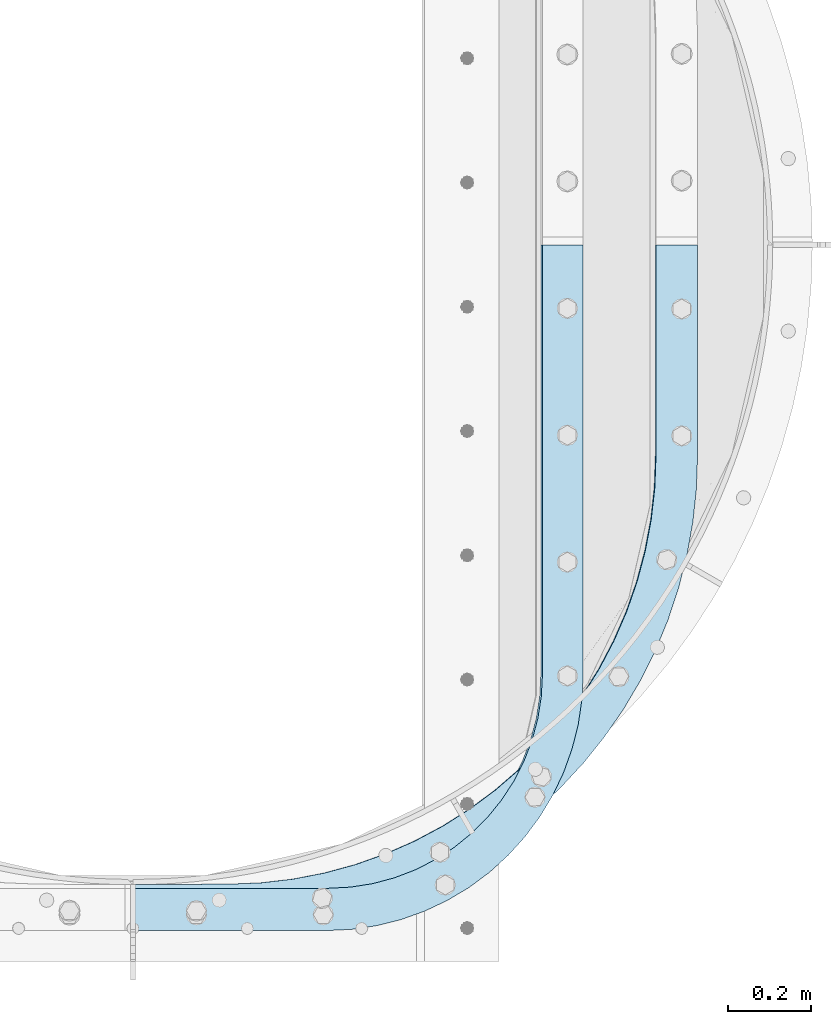
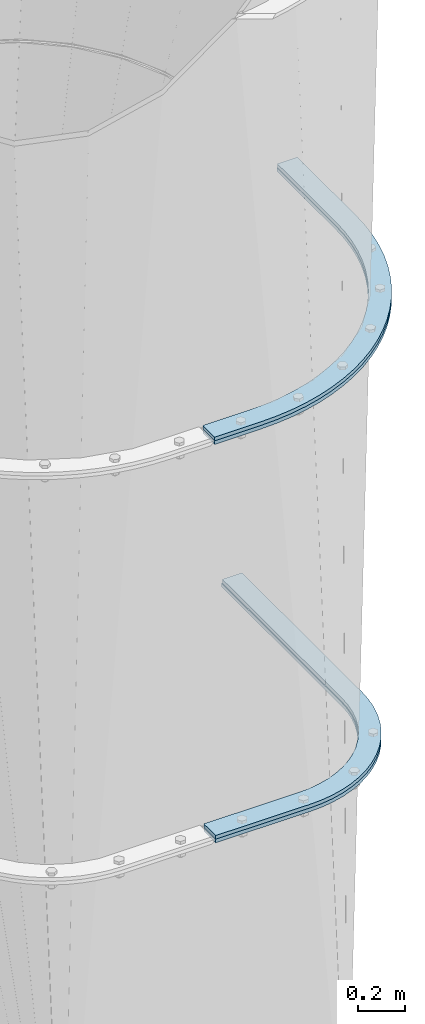
# One storey, part 11 of 15: 4 plates, 3 elements without a shape of their own.
"""IFC2X3 building model written with IfcOpenShell, lengths in millimetres."""

from ifc_helpers import new_model, si_unit, frame, origin_with_axes, place, context, subcontext, project, spatial, faceted_brep, material, type_object, element, aggregate, save


model = new_model("IFC2X3")

# Units and contexts
model_context = context("Model", 3, precision=1e-05, world=origin_with_axes())
body_context = subcontext(model_context, "Body", "Model", "MODEL_VIEW")
ifc_project = project(units=[si_unit("LENGTHUNIT", "METRE", prefix="MILLI"), si_unit("AREAUNIT", "SQUARE_METRE"), si_unit("VOLUMEUNIT", "CUBIC_METRE"), si_unit("MASSUNIT", "GRAM", prefix="KILO"), si_unit("TIMEUNIT", "SECOND"), si_unit("PLANEANGLEUNIT", "RADIAN"), si_unit("SOLIDANGLEUNIT", "STERADIAN"), si_unit("THERMODYNAMICTEMPERATUREUNIT", "DEGREE_CELSIUS"), si_unit("LUMINOUSINTENSITYUNIT", "LUMEN")], contexts=[model_context])

# Site, building, storey
site_placement = place(None, origin_with_axes())
site = spatial("IfcSite", under=ifc_project, at=site_placement, CompositionType="ELEMENT")
building_placement = place(site_placement, origin_with_axes())
building = spatial("IfcBuilding", under=site, at=building_placement, Name="Undefined", CompositionType="ELEMENT")
storey_placement = place(building_placement, origin_with_axes())
storey = spatial("IfcBuildingStorey", under=building, at=storey_placement, Name="Undefined", CompositionType="ELEMENT", Elevation=0.0)

# Assembly, plate
assembly_1_placement = place(storey_placement, origin_with_axes())
assembly_1 = element("IfcElementAssembly", 1, at=assembly_1_placement, inside=storey, Name="TRANSITION", AssemblyPlace="NOTDEFINED", PredefinedType="RIGID_FRAME")
ifc_material = material(Name="STEEL/A36")
plate_type_1 = type_object("IfcPlateType", PredefinedType="NOTDEFINED")
plate_1_placement = place(assembly_1_placement, frame((2235.57307813265, 1720.82092583339, 4192.06000019074), z_axis=(0.0, -1.0, 0.0), x_axis=(-1.0, 0.0, 0.0)))
plate_1 = element("IfcPlate", 2, at=plate_1_placement, type_object=plate_type_1, material=ifc_material, Name="PLATE", context=body_context, shape_type="Brep", body=[
    faceted_brep([(0.0, -9.52499999999964, 0.0), (0.00226665040457874, -9.52499999999964, 506.568496906642), (0.00226665040457874, 9.52499999999964, 506.568496906642), (0.0, 9.52499999999964, 0.0), (2.86552112687696, -9.52499999999964, 586.965399212112), (2.86552112687696, 9.52499999999964, 586.965399212112), (11.4400606208065, -9.52499999999964, 666.955007280796), (11.4400606208065, 9.52499999999964, 666.955007280796), (25.682448871113, -9.52499999999964, 746.132115736726), (25.682448871113, 9.52499999999964, 746.132115736726), (45.5205378522613, -9.52499999999964, 824.095635103739), (45.5205378522613, 9.52499999999964, 824.095635103739), (70.8538332563299, -9.52499999999964, 900.450623614542), (70.8538332563299, 9.52499999999964, 900.450623614542), (101.554003569561, -9.52499999999964, 974.810287877187), (101.554003569561, 9.52499999999964, 974.810287877187), (137.465530164548, -9.52499999999964, 1046.79794226412), (137.465530164548, 9.52499999999964, 1046.79794226412), (178.406495114871, -9.52499999999964, 1116.04891709806), (178.406495114871, 9.52499999999964, 1116.04891709806), (224.169502741328, -9.52499999999964, 1182.2124059684), (224.169502741328, 9.52499999999964, 1182.2124059684), (274.522730221457, -9.52499999999964, 1244.95324282008), (274.522730221457, 9.52499999999964, 1244.95324282008), (329.211101940261, -9.52499999999964, 1303.95359981273), (329.211101940261, 9.52499999999964, 1303.95359981273), (387.957581633183, -9.52499999999964, 1358.9145973492), (387.957581633183, 9.52499999999964, 1358.9145973492), (450.464575775707, -9.52499999999964, 1409.55781811744), (450.464575775707, 9.52499999999964, 1409.55781811744), (516.41544111038, -9.52499999999964, 1455.62671747614), (516.41544111038, 9.52499999999964, 1455.62671747614), (585.476088674554, -9.52499999999964, 1496.88792303938), (585.476088674554, 9.52499999999964, 1496.88792303938), (657.296676203268, -9.52499999999964, 1533.13241687699), (657.296676203268, 9.52499999999964, 1533.13241687699), (731.513380334047, -9.52499999999964, 1564.176594342), (731.513380334047, 9.52499999999964, 1564.176594342), (807.750239636084, -9.52499999999964, 1589.86319416129), (807.750239636084, 9.52499999999964, 1589.86319416129), (885.621059127542, -9.52499999999964, 1610.062095078), (885.621059127542, 9.52499999999964, 1610.062095078), (964.731366633227, -9.52499999999964, 1624.6709750101), (964.731366633227, 9.52499999999964, 1624.6709750101), (1044.68041107224, -9.52499999999964, 1633.61582938589), (1044.68041107224, 9.52499999999964, 1633.61582938589), (1125.06319255282, -9.52499999999964, 1636.85134603082), (1125.06319255282, 9.52499999999964, 1636.85134603082), (1356.09802246094, -9.52499999999964, 1637.92224121094), (1356.09802246094, 9.52499999999964, 1637.92224121094), (1356.09802246094, -9.52499999999964, 1536.322265625), (1356.09802246094, 9.52499999999964, 1536.322265625), (1123.73482538487, -9.52499999999964, 1535.24674210153), (1123.73482538487, 9.52499999999964, 1535.24674210153), (1047.10030478318, -9.52499999999964, 1532.03247607219), (1047.10030478318, 9.52499999999964, 1532.03247607219), (970.918303938195, -9.52499999999964, 1523.11709603465), (970.918303938195, 9.52499999999964, 1523.11709603465), (895.612355762711, -9.52499999999964, 1508.55016693653), (895.612355762711, 9.52499999999964, 1508.55016693653), (821.601122765285, -9.52499999999964, 1488.41267344407), (821.601122765285, 9.52499999999964, 1488.41267344407), (749.2960695011, -9.52499999999964, 1462.8165697089), (749.2960695011, 9.52499999999964, 1462.8165697089), (679.099175039733, -9.52499999999964, 1431.90415696032), (679.099175039733, 9.52499999999964, 1431.90415696032), (611.400698167385, -9.52499999999964, 1395.84729238334), (611.400698167385, 9.52499999999964, 1395.84729238334), (546.57700774787, -9.52499999999964, 1354.84643368071), (546.57700774787, 9.52499999999964, 1354.84643368071), (484.988490304467, -9.52499999999964, 1309.12952463074), (484.988490304467, 9.52499999999964, 1309.12952463074), (426.977546455406, -9.52499999999964, 1258.95072783668), (426.977546455406, 9.52499999999964, 1258.95072783668), (372.866687341763, -9.52499999999964, 1204.58901171272), (372.866687341763, 9.52499999999964, 1204.58901171272), (322.956741630674, -9.52499999999964, 1146.34659956251), (322.956741630674, 9.52499999999964, 1146.34659956251), (277.525183061995, -9.52499999999964, 1084.54728937235), (277.525183061995, 9.52499999999964, 1084.54728937235), (236.824587836399, -9.52499999999964, 1019.5346536602), (236.824587836399, 9.52499999999964, 1019.5346536602), (201.081230421042, -9.52499999999964, 951.670129388405), (201.081230421042, 9.52499999999964, 951.670129388405), (170.493825579402, -9.52499999999964, 881.331008559293), (170.493825579402, 9.52499999999964, 881.331008559293), (145.232423618945, -9.52499999999964, 808.908340664835), (145.232423618945, 9.52499999999964, 808.908340664835), (125.437464998504, -9.52499999999964, 734.804758651724), (125.437464998504, 9.52499999999964, 734.804758651724), (111.218999551242, -9.52499999999964, 659.432240488378), (111.218999551242, 9.52499999999964, 659.432240488378), (102.656074663938, -9.52499999999964, 583.209818778404), (102.656074663938, 9.52499999999964, 583.209818778404), (99.7962958139181, -9.52499999999964, 506.561251153978), (99.7962958139181, 9.52499999999964, 506.561251153978), (99.7946014404297, -9.52499999999964, 0.0), (99.7946014404297, 9.52499999999964, 0.0)], [[[0, 1, 2, 3]], [[1, 4, 5, 2]], [[4, 6, 7, 5]], [[6, 8, 9, 7]], [[8, 10, 11, 9]], [[10, 12, 13, 11]], [[12, 14, 15, 13]], [[14, 16, 17, 15]], [[16, 18, 19, 17]], [[18, 20, 21, 19]], [[20, 22, 23, 21]], [[22, 24, 25, 23]], [[24, 26, 27, 25]], [[26, 28, 29, 27]], [[28, 30, 31, 29]], [[30, 32, 33, 31]], [[32, 34, 35, 33]], [[34, 36, 37, 35]], [[36, 38, 39, 37]], [[38, 40, 41, 39]], [[40, 42, 43, 41]], [[42, 44, 45, 43]], [[44, 46, 47, 45]], [[46, 48, 49, 47]], [[48, 50, 51, 49]], [[50, 52, 53, 51]], [[52, 54, 55, 53]], [[54, 56, 57, 55]], [[56, 58, 59, 57]], [[58, 60, 61, 59]], [[60, 62, 63, 61]], [[62, 64, 65, 63]], [[64, 66, 67, 65]], [[66, 68, 69, 67]], [[68, 70, 71, 69]], [[70, 72, 73, 71]], [[72, 74, 75, 73]], [[74, 76, 77, 75]], [[76, 78, 79, 77]], [[78, 80, 81, 79]], [[80, 82, 83, 81]], [[82, 84, 85, 83]], [[84, 86, 87, 85]], [[86, 88, 89, 87]], [[88, 90, 91, 89]], [[90, 92, 93, 91]], [[92, 94, 95, 93]], [[94, 96, 97, 95]], [[96, 0, 3, 97]], [[5, 7, 9, 11, 13, 15, 17, 19, 21, 23, 25, 27, 29, 31, 33, 35, 37, 39, 41, 43, 45, 47, 49, 51, 53, 55, 57, 59, 61, 63, 65, 67, 69, 71, 73, 75, 77, 79, 81, 83, 85, 87, 89, 91, 93, 95, 97, 3, 2]], [[96, 94, 92, 90, 88, 86, 84, 82, 80, 78, 76, 74, 72, 70, 68, 66, 64, 62, 60, 58, 56, 54, 52, 50, 48, 46, 44, 42, 40, 38, 36, 34, 32, 30, 28, 26, 24, 22, 20, 18, 16, 14, 12, 10, 8, 6, 4, 1, 0]]]),
])
aggregate(assembly_1, [plate_1])

# Assembly, plates
assembly_2_placement = place(storey_placement, origin_with_axes())
assembly_2 = element("IfcElementAssembly", 3, at=assembly_2_placement, inside=storey, Name="TRANSITION", AssemblyPlace="NOTDEFINED", PredefinedType="RIGID_FRAME")
plate_2_placement = place(assembly_2_placement, frame((2235.57307813265, 1720.82092583339, 4173.01), z_axis=(0.0, -1.0, 0.0), x_axis=(-1.0, 0.0, 0.0)))
plate_2 = element("IfcPlate", 4, at=plate_2_placement, type_object=plate_type_1, material=ifc_material, Name="PLATE", context=body_context, shape_type="Brep", body=[
    faceted_brep([(0.0, -9.52499999999964, 0.0), (0.00226665040457874, -9.52499999999964, 506.568496906642), (0.00226665040457874, 9.52499999999964, 506.568496906642), (0.0, 9.52499999999964, 0.0), (2.86552112687696, -9.52499999999964, 586.965399212112), (2.86552112687696, 9.52499999999964, 586.965399212112), (11.4400606208065, -9.52499999999964, 666.955007280796), (11.4400606208065, 9.52499999999964, 666.955007280796), (25.682448871113, -9.52499999999964, 746.132115736726), (25.682448871113, 9.52499999999964, 746.132115736726), (45.5205378522613, -9.52499999999964, 824.095635103739), (45.5205378522613, 9.52499999999964, 824.095635103739), (70.8538332563299, -9.52499999999964, 900.450623614542), (70.8538332563299, 9.52499999999964, 900.450623614542), (101.554003569561, -9.52499999999964, 974.810287877187), (101.554003569561, 9.52499999999964, 974.810287877187), (137.465530164548, -9.52499999999964, 1046.79794226412), (137.465530164548, 9.52499999999964, 1046.79794226412), (178.406495114871, -9.52499999999964, 1116.04891709806), (178.406495114871, 9.52499999999964, 1116.04891709806), (224.169502741328, -9.52499999999964, 1182.2124059684), (224.169502741328, 9.52499999999964, 1182.2124059684), (274.522730221457, -9.52499999999964, 1244.95324282008), (274.522730221457, 9.52499999999964, 1244.95324282008), (329.211101940261, -9.52499999999964, 1303.95359981273), (329.211101940261, 9.52499999999964, 1303.95359981273), (387.957581633183, -9.52499999999964, 1358.9145973492), (387.957581633183, 9.52499999999964, 1358.9145973492), (450.464575775707, -9.52499999999964, 1409.55781811744), (450.464575775707, 9.52499999999964, 1409.55781811744), (516.41544111038, -9.52499999999964, 1455.62671747614), (516.41544111038, 9.52499999999964, 1455.62671747614), (585.476088674554, -9.52499999999964, 1496.88792303938), (585.476088674554, 9.52499999999964, 1496.88792303938), (657.296676203268, -9.52499999999964, 1533.13241687699), (657.296676203268, 9.52499999999964, 1533.13241687699), (731.513380334047, -9.52499999999964, 1564.176594342), (731.513380334047, 9.52499999999964, 1564.176594342), (807.750239636084, -9.52499999999964, 1589.86319416129), (807.750239636084, 9.52499999999964, 1589.86319416129), (885.621059127542, -9.52499999999964, 1610.062095078), (885.621059127542, 9.52499999999964, 1610.062095078), (964.731366633227, -9.52499999999964, 1624.6709750101), (964.731366633227, 9.52499999999964, 1624.6709750101), (1044.68041107224, -9.52499999999964, 1633.61582938589), (1044.68041107224, 9.52499999999964, 1633.61582938589), (1125.06319255282, -9.52499999999964, 1636.85134603082), (1125.06319255282, 9.52499999999964, 1636.85134603082), (1356.09802246094, -9.52499999999964, 1637.92224121094), (1356.09802246094, 9.52499999999964, 1637.92224121094), (1356.09802246094, -9.52499999999964, 1536.322265625), (1356.09802246094, 9.52499999999964, 1536.322265625), (1125.53337021302, -9.52499999999964, 1535.25353104851), (1125.53337021302, 9.52499999999964, 1535.25353104851), (1048.89919630054, -9.52499999999964, 1532.03878036735), (1048.89919630054, 9.52499999999964, 1532.03878036735), (972.717574464455, -9.52499999999964, 1523.1229670218), (972.717574464455, 9.52499999999964, 1523.1229670218), (897.41203190946, -9.52499999999964, 1508.55565794681), (897.41203190946, 9.52499999999964, 1508.55565794681), (823.401225329481, -9.52499999999964, 1488.41783923252), (823.401225329481, 9.52499999999964, 1488.41783923252), (751.096613410651, -9.52499999999964, 1462.82146588676), (751.096613410651, 9.52499999999964, 1462.82146588676), (680.900169351152, -9.52499999999964, 1431.90883942782), (680.900169351152, 9.52499999999964, 1431.90883942782), (613.202146115094, -9.52499999999964, 1395.85181676761), (613.202146115094, 9.52499999999964, 1395.85181676761), (548.378906844311, -9.52499999999964, 1354.8508547834), (548.378906844311, 9.52499999999964, 1354.8508547834), (486.790832489823, -9.52499999999964, 1309.13389588963), (486.790832489823, 9.52499999999964, 1309.13389588963), (428.780318295328, -9.52499999999964, 1258.95510080566), (428.780318295328, 9.52499999999964, 1258.95510080566), (374.669870271166, -9.52499999999964, 1204.59343556431), (374.669870271166, 9.52499999999964, 1204.59343556431), (324.7603122413, -9.52499999999964, 1146.35112061673), (324.7603122413, 9.52499999999964, 1146.35112061673), (279.32911343112, -9.52499999999964, 1084.55195065581), (279.32911343112, 9.52499999999964, 1084.55195065581), (238.628845893756, -9.52499999999964, 1019.53949449874), (238.628845893756, 9.52499999999964, 1019.53949449874), (202.885780350741, -9.52499999999964, 951.67518503657), (202.885780350741, 9.52499999999964, 951.67518503657), (172.298628253365, -9.52499999999964, 881.336309869553), (172.298628253365, 9.52499999999964, 881.336309869553), (147.037437058154, -9.52499999999964, 808.913913799081), (147.037437058154, 9.52499999999964, 808.913913799081), (127.242644858133, -9.52499999999964, 734.810624837339), (127.242644858133, 9.52499999999964, 734.810624837339), (113.024299625579, -9.52499999999964, 659.438415820769), (113.024299625579, 9.52499999999964, 659.438415820769), (104.461447406857, -9.52499999999964, 583.21631407154), (104.461447406857, 9.52499999999964, 583.21631407154), (101.601692870424, -9.52499999999964, 506.568071840215), (101.601692870424, 9.52499999999964, 506.568071840215), (101.599998474121, -9.52499999999964, 0.0), (101.599998474121, 9.52499999999964, 0.0)], [[[0, 1, 2, 3]], [[1, 4, 5, 2]], [[4, 6, 7, 5]], [[6, 8, 9, 7]], [[8, 10, 11, 9]], [[10, 12, 13, 11]], [[12, 14, 15, 13]], [[14, 16, 17, 15]], [[16, 18, 19, 17]], [[18, 20, 21, 19]], [[20, 22, 23, 21]], [[22, 24, 25, 23]], [[24, 26, 27, 25]], [[26, 28, 29, 27]], [[28, 30, 31, 29]], [[30, 32, 33, 31]], [[32, 34, 35, 33]], [[34, 36, 37, 35]], [[36, 38, 39, 37]], [[38, 40, 41, 39]], [[40, 42, 43, 41]], [[42, 44, 45, 43]], [[44, 46, 47, 45]], [[46, 48, 49, 47]], [[48, 50, 51, 49]], [[50, 52, 53, 51]], [[52, 54, 55, 53]], [[54, 56, 57, 55]], [[56, 58, 59, 57]], [[58, 60, 61, 59]], [[60, 62, 63, 61]], [[62, 64, 65, 63]], [[64, 66, 67, 65]], [[66, 68, 69, 67]], [[68, 70, 71, 69]], [[70, 72, 73, 71]], [[72, 74, 75, 73]], [[74, 76, 77, 75]], [[76, 78, 79, 77]], [[78, 80, 81, 79]], [[80, 82, 83, 81]], [[82, 84, 85, 83]], [[84, 86, 87, 85]], [[86, 88, 89, 87]], [[88, 90, 91, 89]], [[90, 92, 93, 91]], [[92, 94, 95, 93]], [[94, 96, 97, 95]], [[96, 0, 3, 97]], [[5, 7, 9, 11, 13, 15, 17, 19, 21, 23, 25, 27, 29, 31, 33, 35, 37, 39, 41, 43, 45, 47, 49, 51, 53, 55, 57, 59, 61, 63, 65, 67, 69, 71, 73, 75, 77, 79, 81, 83, 85, 87, 89, 91, 93, 95, 97, 3, 2]], [[96, 94, 92, 90, 88, 86, 84, 82, 80, 78, 76, 74, 72, 70, 68, 66, 64, 62, 60, 58, 56, 54, 52, 50, 48, 46, 44, 42, 40, 38, 36, 34, 32, 30, 28, 26, 24, 22, 20, 18, 16, 14, 12, 10, 8, 6, 4, 1, 0]]]),
])
plate_type_2 = type_object("IfcPlateType", PredefinedType="NOTDEFINED")
plate_3_placement = place(assembly_2_placement, frame((1960.91443882889, 73.9726734030219, 2110.315), z_axis=(-1.0, 0.0, 0.0), x_axis=(0.0, 1.0, 0.0)))
plate_3 = element("IfcPlate", 5, at=plate_3_placement, type_object=plate_type_2, material=ifc_material, Name="PLATE", context=body_context, shape_type="Brep", body=[
    faceted_brep([(-5.43179524470361e-07, -9.52500000000009, 615.950011663852), (-9.5367431640625e-07, -9.52500000000009, 1081.43933105469), (-1.52587881530053e-06, 9.52500000000009, 1081.43933105469), (-5.43179524470361e-07, 9.52500000000009, 615.950011663852), (101.599998474121, -9.52500000000009, 1081.43933105469), (101.599998474121, 9.52500000000009, 1081.43933105469), (101.599998474121, -9.52500000000009, 612.179878234863), (101.599998474121, 9.52500000000009, 612.179878234863), (104.417661457707, -9.52500000000009, 558.41566570511), (104.417661457707, 9.52500000000009, 558.41566570511), (112.839779503182, -9.52500000000009, 505.240505138718), (112.839779503182, 9.52500000000009, 505.240505138718), (126.7740781228, -9.52500000000009, 453.236994722469), (126.7740781228, 9.52500000000009, 453.236994722469), (146.067890224943, -9.52500000000009, 402.974895798919), (146.067890224943, 9.52500000000009, 402.974895798919), (170.509828766731, -9.52500000000009, 355.004890441895), (170.509828766731, 9.52500000000009, 355.004890441895), (199.832102754696, -9.52500000000009, 309.852548068456), (199.832102754696, 9.52500000000009, 309.852548068456), (233.713451218945, -9.52500000000009, 268.012567190381), (233.713451218945, 9.52500000000009, 268.012567190381), (271.782663015576, -9.52500000000009, 229.94335539375), (271.782663015576, 9.52500000000009, 229.94335539375), (313.622643893651, -9.52500000000009, 196.062006929501), (313.622643893651, 9.52500000000009, 196.062006929501), (358.77498626709, -9.52500000000009, 166.739732941536), (358.77498626709, 9.52500000000009, 166.739732941536), (406.744991624115, -9.52500000000009, 142.297794399747), (406.744991624115, 9.52500000000009, 142.297794399747), (457.007090547665, -9.52500000000009, 123.003982297604), (457.007090547665, 9.52500000000009, 123.003982297604), (509.010600963913, -9.52500000000009, 109.069683677987), (509.010600963913, 9.52500000000009, 109.069683677987), (562.185761530305, -9.52500000000009, 100.647565632512), (562.185761530305, 9.52500000000009, 100.647565632512), (615.949974060059, -9.52500000000009, 97.8299026489258), (615.949974060059, 9.52500000000009, 97.8299026489258), (1646.87729611779, -9.52500114440909, 97.8299026491594), (1646.87731933594, 9.52500000000009, 97.8299026489258), (1646.87731933594, -9.52500000000009, 0.0), (1646.87731933594, 9.52500000000009, 0.0), (615.950011663852, -9.52500000000009, 0.0), (615.950011663852, 9.52500000000009, 0.0), (555.576352915146, -9.52500000000009, 2.96596766171297), (555.576352915146, 9.52500000000009, 2.96596766171297), (495.784125503137, -9.52500000000009, 11.8353067569387), (495.784125503137, 9.52500000000009, 11.8353067569387), (437.149161262912, -9.52500000000009, 26.5226007018123), (437.149161262912, 9.52500000000009, 26.5226007018123), (380.236146952604, -9.52500000000009, 46.8864028269114), (380.236146952604, 9.52500000000009, 46.8864028269114), (325.593186011224, -9.52500000000009, 72.7305985860049), (325.593186011224, 9.52500000000009, 72.7305985860049), (273.746520022929, -9.52500000000009, 103.806294246338), (273.746520022929, 9.52500000000009, 103.806294246338), (225.195460722895, -9.52500000000009, 139.814213871333), (225.195460722895, 9.52500000000009, 139.814213871333), (180.407581352366, -9.52500000000009, 180.40758151146), (180.407581352366, 9.52500000000009, 180.40758151146), (139.814213672743, -9.52500000000009, 225.195460846191), (139.814213672743, 9.52500000000009, 225.195460846191), (103.806294004932, -9.52500000000009, 273.746520114471), (103.806294004932, 9.52500000000009, 273.746520114471), (72.7305982988784, -9.52500000000009, 325.593186075362), (72.7305982988784, 9.52500000000009, 325.593186075362), (46.8864024915977, -9.52500000000009, 380.236146993951), (46.8864024915977, 9.52500000000009, 380.236146993951), (26.5226003163094, -9.52500000000009, 437.149161286301), (26.5226003163094, 9.52500000000009, 437.149161286301), (11.8353063197283, -9.52500000000009, 495.784125513574), (11.8353063197283, 9.52500000000009, 495.784125513574), (2.96596717177431, -9.52500000000009, 555.576352917761), (2.96596717177431, 9.52500000000009, 555.576352917761)], [[[0, 1, 2, 3]], [[1, 4, 5, 2]], [[4, 6, 7, 5]], [[6, 8, 9, 7]], [[8, 10, 11, 9]], [[10, 12, 13, 11]], [[12, 14, 15, 13]], [[14, 16, 17, 15]], [[16, 18, 19, 17]], [[18, 20, 21, 19]], [[20, 22, 23, 21]], [[22, 24, 25, 23]], [[24, 26, 27, 25]], [[26, 28, 29, 27]], [[28, 30, 31, 29]], [[30, 32, 33, 31]], [[32, 34, 35, 33]], [[34, 36, 37, 35]], [[36, 38, 39, 37]], [[38, 40, 41, 39]], [[40, 42, 43, 41]], [[42, 44, 45, 43]], [[44, 46, 47, 45]], [[46, 48, 49, 47]], [[48, 50, 51, 49]], [[50, 52, 53, 51]], [[52, 54, 55, 53]], [[54, 56, 57, 55]], [[56, 58, 59, 57]], [[58, 60, 61, 59]], [[60, 62, 63, 61]], [[62, 64, 65, 63]], [[64, 66, 67, 65]], [[66, 68, 69, 67]], [[68, 70, 71, 69]], [[70, 72, 73, 71]], [[72, 0, 3, 73]], [[5, 7, 9, 11, 13, 15, 17, 19, 21, 23, 25, 27, 29, 31, 33, 35, 37, 39, 41, 43, 45, 47, 49, 51, 53, 55, 57, 59, 61, 63, 65, 67, 69, 71, 73, 3, 2]], [[72, 70, 68, 66, 64, 62, 60, 58, 56, 54, 52, 50, 48, 46, 44, 42, 40, 38, 36, 34, 32, 30, 28, 26, 24, 22, 20, 18, 16, 14, 12, 10, 8, 6, 4, 1, 0]]]),
])
aggregate(assembly_2, [plate_2, plate_3])

# Assembly, plate
assembly_3_placement = place(storey_placement, origin_with_axes())
assembly_3 = element("IfcElementAssembly", 6, at=assembly_3_placement, inside=storey, Name="TRANSITION", AssemblyPlace="NOTDEFINED", PredefinedType="RIGID_FRAME")
plate_4_placement = place(assembly_3_placement, frame((1960.91443882889, 73.9726734030219, 2091.265), z_axis=(-1.0, 0.0, 0.0), x_axis=(0.0, 1.0, 0.0)))
plate_4 = element("IfcPlate", 7, at=plate_4_placement, type_object=plate_type_2, material=ifc_material, Name="PLATE", context=body_context, shape_type="Brep", body=[
    faceted_brep([(-5.43179524470361e-07, -9.52500000000009, 615.950011663852), (-9.5367431640625e-07, -9.52500000000009, 1081.43933105469), (-1.52587881530053e-06, 9.52500000000009, 1081.43933105469), (-5.43179524470361e-07, 9.52500000000009, 615.950011663852), (101.599998474121, -9.52500000000009, 1081.43933105469), (101.599998474121, 9.52500000000009, 1081.43933105469), (101.599998474121, -9.52500000000009, 615.949974060059), (101.599998474121, 9.52500000000009, 615.949974060059), (104.417661457707, -9.52500000000009, 562.185761530306), (104.417661457707, 9.52500000000009, 562.185761530306), (112.839779503182, -9.52500000000009, 509.010600963913), (112.839779503182, 9.52500000000009, 509.010600963913), (126.7740781228, -9.52500000000009, 457.007090547665), (126.7740781228, 9.52500000000009, 457.007090547665), (146.067890224943, -9.52500000000009, 406.744991624115), (146.067890224943, 9.52500000000009, 406.744991624115), (170.509828766731, -9.52500000000009, 358.77498626709), (170.509828766731, 9.52500000000009, 358.77498626709), (199.832102754696, -9.52500000000009, 313.622643893651), (199.832102754696, 9.52500000000009, 313.622643893651), (233.713451218945, -9.52500000000009, 271.782663015577), (233.713451218945, 9.52500000000009, 271.782663015577), (271.782663015576, -9.52500000000009, 233.713451218945), (271.782663015576, 9.52500000000009, 233.713451218945), (313.622643893651, -9.52500000000009, 199.832102754696), (313.622643893651, 9.52500000000009, 199.832102754696), (358.77498626709, -9.52500000000009, 170.509828766731), (358.77498626709, 9.52500000000009, 170.509828766731), (406.744991624115, -9.52500000000009, 146.067890224943), (406.744991624115, 9.52500000000009, 146.067890224943), (457.007090547665, -9.52500000000009, 126.7740781228), (457.007090547665, 9.52500000000009, 126.7740781228), (509.010600963913, -9.52500000000009, 112.839779503182), (509.010600963913, 9.52500000000009, 112.839779503182), (562.185761530305, -9.52500000000009, 104.417661457707), (562.185761530305, 9.52500000000009, 104.417661457707), (615.949974060059, -9.52500000000009, 101.599998474121), (615.949974060059, 9.52500000000009, 101.599998474121), (1646.87731933594, -9.52500000000009, 101.599998474121), (1646.87733404866, 9.52499923706046, 101.599998473973), (1646.87731933594, -9.52500000000009, 0.0), (1646.87731933594, 9.52500000000009, 0.0), (615.950011663852, -9.52500000000009, 0.0), (615.950011663852, 9.52500000000009, 0.0), (555.576352915146, -9.52500000000009, 2.96596766171297), (555.576352915146, 9.52500000000009, 2.96596766171297), (495.784125503137, -9.52500000000009, 11.8353067569387), (495.784125503137, 9.52500000000009, 11.8353067569387), (437.149161262912, -9.52500000000009, 26.5226007018123), (437.149161262912, 9.52500000000009, 26.5226007018123), (380.236146952604, -9.52500000000009, 46.8864028269114), (380.236146952604, 9.52500000000009, 46.8864028269114), (325.593186011224, -9.52500000000009, 72.7305985860049), (325.593186011224, 9.52500000000009, 72.7305985860049), (273.746520022929, -9.52500000000009, 103.806294246338), (273.746520022929, 9.52500000000009, 103.806294246338), (225.195460722895, -9.52500000000009, 139.814213871333), (225.195460722895, 9.52500000000009, 139.814213871333), (180.407581352366, -9.52500000000009, 180.40758151146), (180.407581352366, 9.52500000000009, 180.40758151146), (139.814213672743, -9.52500000000009, 225.195460846191), (139.814213672743, 9.52500000000009, 225.195460846191), (103.806294004932, -9.52500000000009, 273.746520114471), (103.806294004932, 9.52500000000009, 273.746520114471), (72.7305982988784, -9.52500000000009, 325.593186075362), (72.7305982988784, 9.52500000000009, 325.593186075362), (46.8864024915977, -9.52500000000009, 380.236146993951), (46.8864024915977, 9.52500000000009, 380.236146993951), (26.5226003163094, -9.52500000000009, 437.149161286301), (26.5226003163094, 9.52500000000009, 437.149161286301), (11.8353063197283, -9.52500000000009, 495.784125513574), (11.8353063197283, 9.52500000000009, 495.784125513574), (2.96596717177431, -9.52500000000009, 555.576352917761), (2.96596717177431, 9.52500000000009, 555.576352917761)], [[[0, 1, 2, 3]], [[1, 4, 5, 2]], [[4, 6, 7, 5]], [[6, 8, 9, 7]], [[8, 10, 11, 9]], [[10, 12, 13, 11]], [[12, 14, 15, 13]], [[14, 16, 17, 15]], [[16, 18, 19, 17]], [[18, 20, 21, 19]], [[20, 22, 23, 21]], [[22, 24, 25, 23]], [[24, 26, 27, 25]], [[26, 28, 29, 27]], [[28, 30, 31, 29]], [[30, 32, 33, 31]], [[32, 34, 35, 33]], [[34, 36, 37, 35]], [[36, 38, 39, 37]], [[38, 40, 41, 39]], [[40, 42, 43, 41]], [[42, 44, 45, 43]], [[44, 46, 47, 45]], [[46, 48, 49, 47]], [[48, 50, 51, 49]], [[50, 52, 53, 51]], [[52, 54, 55, 53]], [[54, 56, 57, 55]], [[56, 58, 59, 57]], [[58, 60, 61, 59]], [[60, 62, 63, 61]], [[62, 64, 65, 63]], [[64, 66, 67, 65]], [[66, 68, 69, 67]], [[68, 70, 71, 69]], [[70, 72, 73, 71]], [[72, 0, 3, 73]], [[5, 7, 9, 11, 13, 15, 17, 19, 21, 23, 25, 27, 29, 31, 33, 35, 37, 39, 41, 43, 45, 47, 49, 51, 53, 55, 57, 59, 61, 63, 65, 67, 69, 71, 73, 3, 2]], [[72, 70, 68, 66, 64, 62, 60, 58, 56, 54, 52, 50, 48, 46, 44, 42, 40, 38, 36, 34, 32, 30, 28, 26, 24, 22, 20, 18, 16, 14, 12, 10, 8, 6, 4, 1, 0]]]),
])
aggregate(assembly_3, [plate_4])

save(model, "model.ifc")
